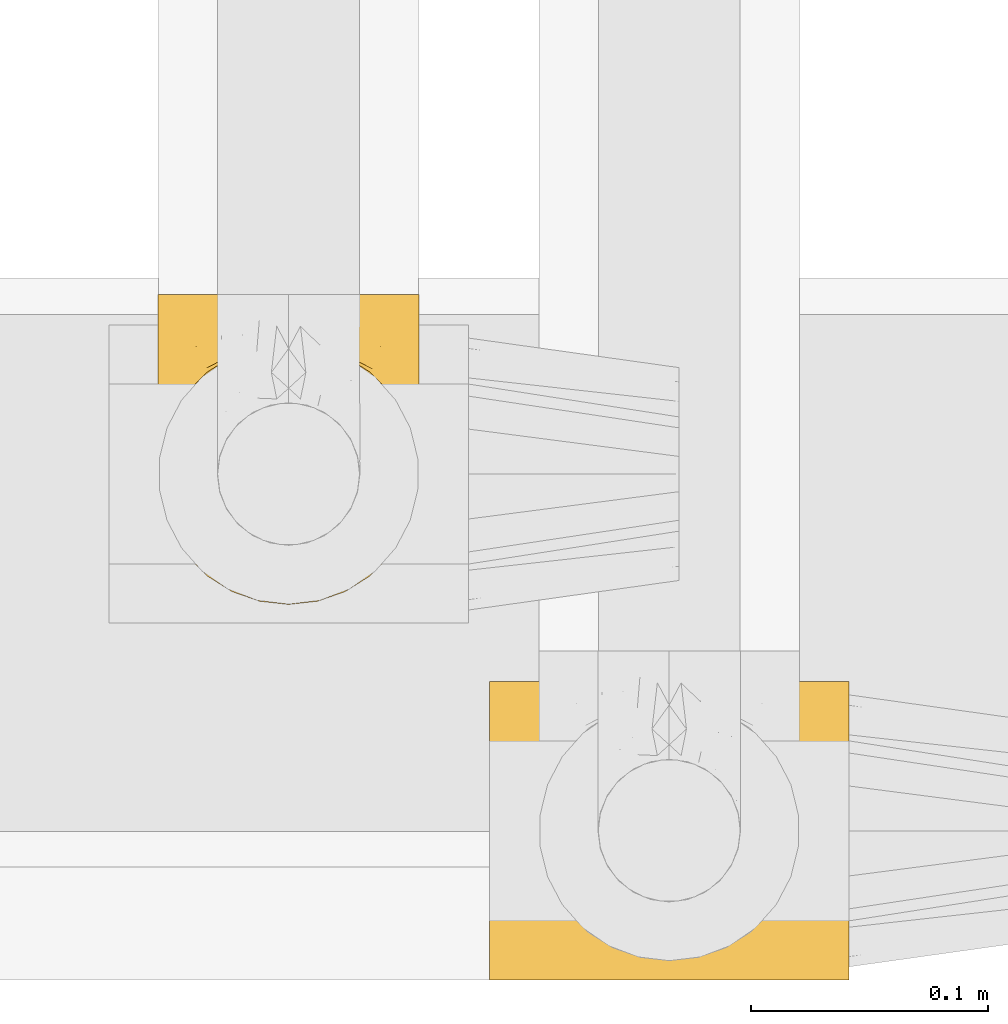
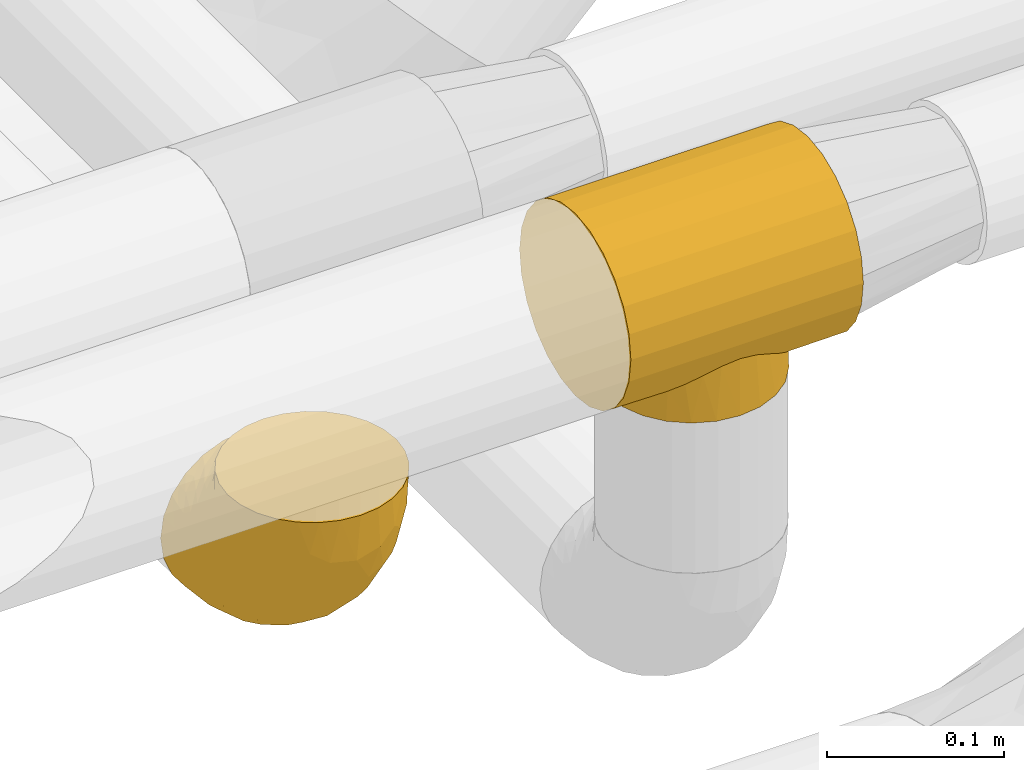
# One storey, part 183 of 827: 2 coverings.
"""IFC2X3 building model written with IfcOpenShell, lengths in millimetres."""

from ifc_helpers import new_model, entity, si_unit, converted_unit, derived_unit, direction, frame, origin, place, context, subcontext, project, spatial, faceted_brep, element, save


model = new_model("IFC2X3")

# Units and contexts
model_context = context("Model", 3, precision=0.01, world=origin(), true_north=direction((6.12303176911189e-17, 1.0)))
body_context = subcontext(model_context, "Body", "Model", "MODEL_VIEW")
ifc_project = project(units=[si_unit("LENGTHUNIT", "METRE", prefix="MILLI"), si_unit("AREAUNIT", "SQUARE_METRE"), si_unit("VOLUMEUNIT", "CUBIC_METRE"), converted_unit("PLANEANGLEUNIT", "DEGREE", entity("IfcRatioMeasure", 0.0174532925199433), si_unit("PLANEANGLEUNIT", "RADIAN"), dimensions=[0, 0, 0, 0, 0, 0, 0]), si_unit("MASSUNIT", "GRAM", prefix="KILO"), derived_unit("MASSDENSITYUNIT", [(si_unit("MASSUNIT", "GRAM", prefix="KILO"), 1), (si_unit("LENGTHUNIT", "METRE"), -3)]), derived_unit("MOMENTOFINERTIAUNIT", [(si_unit("LENGTHUNIT", "METRE"), 4)]), si_unit("TIMEUNIT", "SECOND"), si_unit("FREQUENCYUNIT", "HERTZ"), si_unit("THERMODYNAMICTEMPERATUREUNIT", "DEGREE_CELSIUS"), derived_unit("THERMALTRANSMITTANCEUNIT", [(si_unit("MASSUNIT", "GRAM", prefix="KILO"), 1), (si_unit("THERMODYNAMICTEMPERATUREUNIT", "KELVIN"), -1), (si_unit("TIMEUNIT", "SECOND"), -3)]), derived_unit("VOLUMETRICFLOWRATEUNIT", [(si_unit("LENGTHUNIT", "METRE"), 3), (si_unit("TIMEUNIT", "SECOND"), -1)]), derived_unit("MASSFLOWRATEUNIT", [(si_unit("MASSUNIT", "GRAM", prefix="KILO"), 1), (si_unit("TIMEUNIT", "SECOND"), -1)]), derived_unit("ROTATIONALFREQUENCYUNIT", [(si_unit("TIMEUNIT", "SECOND"), -1)]), si_unit("ELECTRICCURRENTUNIT", "AMPERE"), si_unit("ELECTRICVOLTAGEUNIT", "VOLT"), si_unit("POWERUNIT", "WATT"), si_unit("FORCEUNIT", "NEWTON", prefix="KILO"), si_unit("ILLUMINANCEUNIT", "LUX"), si_unit("LUMINOUSFLUXUNIT", "LUMEN"), si_unit("LUMINOUSINTENSITYUNIT", "CANDELA"), derived_unit("USERDEFINED", [(si_unit("MASSUNIT", "GRAM", prefix="KILO"), -1), (si_unit("LENGTHUNIT", "METRE"), -2), (si_unit("TIMEUNIT", "SECOND"), 3), (si_unit("LUMINOUSFLUXUNIT", "LUMEN"), 1)]), derived_unit("LINEARVELOCITYUNIT", [(si_unit("LENGTHUNIT", "METRE"), 1), (si_unit("TIMEUNIT", "SECOND"), -1)]), si_unit("PRESSUREUNIT", "PASCAL"), derived_unit("USERDEFINED", [(si_unit("LENGTHUNIT", "METRE"), -2), (si_unit("MASSUNIT", "GRAM", prefix="KILO"), 1), (si_unit("TIMEUNIT", "SECOND"), -2)]), derived_unit("LINEARFORCEUNIT", [(si_unit("MASSUNIT", "GRAM", prefix="KILO"), 1), (si_unit("LENGTHUNIT", "METRE"), 1), (si_unit("TIMEUNIT", "SECOND"), -2), (si_unit("LENGTHUNIT", "METRE"), -1)]), derived_unit("PLANARFORCEUNIT", [(si_unit("MASSUNIT", "GRAM", prefix="KILO"), 1), (si_unit("LENGTHUNIT", "METRE"), 1), (si_unit("TIMEUNIT", "SECOND"), -2), (si_unit("LENGTHUNIT", "METRE"), -2)])], contexts=[model_context])

# Site, building, storey
site_placement = place(None, origin())
site = spatial("IfcSite", under=ifc_project, at=site_placement, CompositionType="ELEMENT")
building_placement = place(site_placement, origin())
building = spatial("IfcBuilding", under=site, at=building_placement, CompositionType="ELEMENT")
storey_placement = place(building_placement, frame((0.0, 0.0, 28200.0)))
storey = spatial("IfcBuildingStorey", under=building, at=storey_placement, Name="08", CompositionType="ELEMENT", Elevation=28200.0)

# Coverings
covering_1_placement = place(storey_placement, frame((36553.64, 6201.06, 3029.92)))
element("IfcCovering", 1, at=covering_1_placement, inside=storey, Name=":ADSK_", ObjectType=":ADSK_", PredefinedType="INSULATION", context=body_context, shape_type="Brep", body=[
    faceted_brep([(152.0, 96.09, 124.73), (152.0, 80.87, 131.01), (152.0, 64.55, 133.13), (152.0, 48.24, 130.96), (152.0, 33.04, 124.64), (152.0, 20.0, 114.6), (152.0, 10.0, 101.53), (152.0, 3.72, 86.31), (152.0, 1.6, 69.99), (152.0, 3.77, 53.67), (152.0, 10.09, 38.48), (152.0, 15.11, 31.95), (152.0, 20.13, 25.43), (152.0, 26.66, 20.43), (152.0, 33.2, 15.43), (152.0, 40.81, 12.29), (152.0, 48.42, 9.16), (152.0, 52.5, 8.62), (152.0, 56.58, 8.09), (152.0, 60.66, 7.56), (152.0, 64.74, 7.03), (152.0, 68.82, 7.57), (152.0, 72.9, 8.12), (152.0, 76.97, 8.66), (152.0, 81.05, 9.2), (152.0, 88.65, 12.36), (152.0, 96.25, 15.52), (152.0, 102.77, 20.54), (152.0, 109.29, 25.56), (152.0, 114.29, 32.1), (152.0, 119.29, 38.64), (152.0, 125.57, 53.85), (152.0, 127.7, 70.17), (152.0, 125.52, 86.49), (152.0, 119.2, 101.69), (152.0, 109.16, 114.73), (0.0, 1.6, 69.99), (0.0, 3.72, 86.31), (0.0, 10.0, 101.53), (0.0, 20.0, 114.6), (0.0, 33.04, 124.64), (0.0, 48.24, 130.96), (0.0, 64.55, 133.13), (0.0, 80.87, 131.01), (0.0, 96.09, 124.73), (0.0, 109.16, 114.73), (0.0, 119.2, 101.69), (0.0, 125.52, 86.49), (0.0, 127.7, 70.17), (0.0, 125.57, 53.85), (0.0, 119.29, 38.64), (0.0, 114.29, 32.1), (0.0, 109.29, 25.56), (0.0, 102.77, 20.54), (0.0, 96.25, 15.52), (0.0, 88.65, 12.36), (0.0, 81.05, 9.2), (0.0, 76.97, 8.66), (0.0, 72.9, 8.12), (0.0, 68.82, 7.57), (0.0, 64.74, 7.03), (0.0, 60.66, 7.56), (0.0, 56.58, 8.09), (0.0, 52.5, 8.62), (0.0, 48.42, 9.16), (0.0, 40.81, 12.29), (0.0, 33.2, 15.43), (0.0, 26.66, 20.43), (0.0, 20.13, 25.43), (0.0, 15.11, 31.95), (0.0, 10.09, 38.48), (0.0, 3.77, 53.67), (76.0, 9.54, 39.44), (37.61, 25.12, 20.96), (45.48, 18.77, 26.83), (54.43, 13.94, 32.6), (126.44, 42.42, 11.08), (64.6, 10.74, 37.39), (106.52, 18.77, 26.83), (97.57, 13.94, 32.6), (87.4, 10.74, 37.39), (131.15, 64.74, 7.03), (20.85, 64.74, 7.03), (114.39, 25.12, 20.96), (121.12, 33.01, 15.54), (21.46, 58.95, 7.56), (28.22, 37.72, 13.31), (25.56, 42.42, 11.08), (22.08, 53.17, 8.08), (30.88, 33.01, 15.54), (128.18, 47.79, 9.58), (129.92, 53.17, 8.08), (23.82, 47.79, 9.58), (130.54, 58.95, 7.56), (123.78, 37.72, 13.31), (21.46, 70.52, 7.58), (22.08, 76.31, 8.12), (30.88, 96.44, 15.64), (28.22, 91.74, 13.39), (126.44, 87.04, 11.14), (123.78, 91.74, 13.39), (25.56, 87.04, 11.14), (23.82, 81.67, 9.63), (129.92, 76.31, 8.12), (130.54, 70.52, 7.58), (128.18, 81.67, 9.63), (121.12, 96.44, 15.64), (114.39, 104.31, 21.07), (45.48, 110.64, 26.96), (54.43, 115.46, 32.75), (37.61, 104.31, 21.07), (64.6, 118.65, 37.54), (76.0, 119.84, 39.6), (97.57, 115.46, 32.75), (106.52, 110.64, 26.96), (87.4, 118.65, 37.54), (76.0, 9.6, 0.0), (61.73, 11.48, 0.0), (48.42, 16.99, 0.01), (37.0, 25.75, 0.02), (28.24, 37.17, 0.04), (25.48, 43.82, 0.05), (22.73, 50.47, 0.06), (21.79, 57.61, 0.07), (20.85, 64.75, 0.08), (21.79, 71.89, 0.09), (22.73, 79.02, 0.1), (25.48, 85.67, 0.11), (28.24, 92.32, 0.12), (37.0, 103.75, 0.14), (48.42, 112.51, 0.15), (61.73, 118.02, 0.16), (76.0, 119.9, 0.16), (90.27, 118.02, 0.16), (103.57, 112.51, 0.15), (115.0, 103.75, 0.14), (123.76, 92.32, 0.12), (126.52, 85.67, 0.11), (129.27, 79.02, 0.1), (130.21, 71.89, 0.09), (131.15, 64.75, 0.08), (130.21, 57.61, 0.07), (129.27, 50.47, 0.06), (126.52, 43.82, 0.05), (123.76, 37.17, 0.04), (115.0, 25.75, 0.02), (103.57, 16.99, 0.01), (90.27, 11.48, 0.0)], [[[0, 1, 2, 3, 4, 5, 6, 7, 8, 9, 10, 11, 12, 13, 14, 15, 16, 17, 18, 19, 20, 21, 22, 23, 24, 25, 26, 27, 28, 29, 30, 31, 32, 33, 34, 35]], [[36, 37, 38, 39, 40, 41, 42, 43, 44, 45, 46, 47, 48, 49, 50, 51, 52, 53, 54, 55, 56, 57, 58, 59, 60, 61, 62, 63, 64, 65, 66, 67, 68, 69, 70, 71]], [[40, 39, 5, 4]], [[2, 42, 41, 3]], [[4, 3, 41, 40]], [[6, 38, 37, 7]], [[7, 37, 36, 8]], [[5, 39, 38, 6]], [[71, 9, 8, 36]], [[70, 72, 71]], [[73, 68, 67]], [[74, 75, 69]], [[76, 16, 15]], [[77, 70, 75]], [[78, 11, 79]], [[69, 68, 74]], [[77, 72, 70]], [[9, 71, 72]], [[10, 9, 72]], [[72, 80, 10]], [[79, 11, 10]], [[19, 81, 20]], [[82, 61, 60]], [[12, 11, 78]], [[83, 12, 78]], [[84, 13, 83]], [[79, 10, 80]], [[75, 70, 69]], [[73, 74, 68]], [[85, 62, 61]], [[86, 66, 65]], [[87, 65, 64]], [[88, 64, 63, 62]], [[73, 67, 89]], [[16, 76, 90, 91]], [[89, 67, 66]], [[85, 61, 82]], [[88, 62, 85]], [[65, 87, 86]], [[64, 88, 92, 87]], [[18, 91, 93]], [[84, 14, 13]], [[94, 14, 84]], [[15, 94, 76]], [[91, 18, 17, 16]], [[83, 13, 12]], [[19, 18, 93]], [[81, 19, 93]], [[14, 94, 15]], [[66, 86, 89]], [[58, 95, 59]], [[96, 58, 57, 56]], [[58, 96, 95]], [[97, 98, 54]], [[25, 99, 100]], [[101, 55, 98]], [[53, 97, 54]], [[56, 101, 102, 96]], [[103, 24, 23, 22]], [[103, 22, 104]], [[81, 21, 20]], [[59, 82, 60]], [[104, 22, 21]], [[104, 21, 81]], [[105, 99, 24, 103]], [[82, 59, 95]], [[106, 107, 27]], [[108, 51, 109]], [[99, 25, 24]], [[100, 26, 25]], [[101, 56, 55]], [[97, 53, 110]], [[53, 52, 110]], [[54, 98, 55]], [[52, 51, 108]], [[50, 111, 109]], [[109, 51, 50]], [[26, 100, 106]], [[112, 49, 31]], [[50, 112, 111]], [[112, 50, 49]], [[49, 48, 32, 31]], [[113, 30, 29]], [[113, 29, 114]], [[27, 26, 106]], [[28, 107, 114]], [[29, 28, 114]], [[115, 30, 113]], [[115, 112, 30]], [[30, 112, 31]], [[107, 28, 27]], [[108, 110, 52]], [[33, 47, 46, 34]], [[34, 46, 45, 35]], [[48, 47, 33, 32]], [[0, 44, 43, 1]], [[1, 43, 42, 2]], [[35, 45, 44, 0]], [[116, 117, 118, 119, 120, 121, 122, 123, 124, 125, 126, 127, 128, 129, 130, 131, 132, 133, 134, 135, 136, 137, 138, 139, 140, 141, 142, 143, 144, 145, 146, 147]], [[88, 123, 122]], [[121, 120, 87]], [[121, 92, 122]], [[119, 89, 120]], [[124, 85, 82]], [[124, 123, 85]], [[92, 121, 87]], [[120, 89, 86, 87]], [[88, 122, 92]], [[123, 88, 85]], [[119, 73, 89]], [[74, 73, 118]], [[118, 73, 119]], [[75, 118, 117]], [[77, 117, 116]], [[74, 118, 75]], [[77, 75, 117]], [[72, 77, 116]], [[80, 116, 147]], [[147, 146, 79]], [[83, 146, 145]], [[83, 78, 146]], [[72, 116, 80]], [[80, 147, 79]], [[146, 78, 79]], [[145, 144, 84]], [[142, 91, 90]], [[142, 90, 143]], [[140, 81, 93]], [[91, 142, 141]], [[144, 76, 94, 84]], [[76, 144, 143]], [[91, 141, 93]], [[143, 90, 76]], [[140, 93, 141]], [[145, 84, 83]], [[103, 139, 138]], [[137, 136, 99]], [[135, 106, 136]], [[140, 104, 81]], [[140, 139, 104]], [[105, 137, 99]], [[136, 106, 100, 99]], [[103, 138, 105]], [[137, 105, 138]], [[135, 107, 106]], [[114, 107, 134]], [[134, 107, 135]], [[113, 134, 133]], [[115, 133, 132]], [[114, 134, 113]], [[115, 113, 133]], [[112, 115, 132]], [[139, 103, 104]], [[111, 132, 131]], [[131, 130, 109]], [[110, 130, 129]], [[110, 108, 130]], [[112, 132, 111]], [[111, 131, 109]], [[130, 108, 109]], [[124, 95, 125]], [[97, 129, 128]], [[126, 102, 127]], [[95, 124, 82]], [[96, 126, 125]], [[128, 101, 98, 97]], [[101, 128, 127]], [[96, 125, 95]], [[127, 102, 101]], [[126, 96, 102]], [[129, 97, 110]]]),
])
covering_2_placement = place(storey_placement, frame((36411.97, 6359.82, 2793.25)))
element("IfcCovering", 2, at=covering_2_placement, inside=storey, Name=":ADSK_", ObjectType=":ADSK_", PredefinedType="INSULATION", context=body_context, shape_type="Brep", body=[
    faceted_brep([(1.6, 56.75, 132.75), (2.98, 44.47, 132.75), (7.06, 32.81, 132.75), (13.63, 22.35, 132.75), (22.37, 13.62, 132.75), (32.83, 7.05, 132.75), (44.49, 2.97, 132.75), (56.75, 1.6, 132.75), (69.02, 2.98, 132.75), (80.68, 7.06, 132.75), (91.14, 13.63, 132.75), (99.87, 22.37, 132.75), (106.44, 32.83, 132.75), (110.52, 44.49, 132.75), (111.9, 56.75, 132.75), (110.94, 65.19, 132.75), (110.51, 69.02, 132.75), (108.47, 74.85, 132.75), (106.43, 80.68, 132.75), (99.86, 91.14, 132.75), (91.12, 99.87, 132.75), (80.66, 106.44, 132.75), (69.0, 110.52, 132.75), (56.75, 111.9, 132.75), (44.47, 110.51, 132.75), (32.81, 106.43, 132.75), (22.35, 99.86, 132.75), (13.62, 91.12, 132.75), (7.05, 80.66, 132.75), (5.01, 74.83, 132.75), (2.97, 69.0, 132.75), (2.55, 65.19, 132.75), (71.02, 132.75, 110.02), (84.32, 132.75, 104.51), (95.74, 132.75, 95.74), (100.12, 132.75, 90.03), (104.51, 132.75, 84.32), (110.02, 132.75, 71.02), (110.78, 132.75, 65.22), (111.34, 132.75, 60.98), (111.9, 132.75, 56.75), (110.02, 132.75, 42.47), (104.51, 132.75, 29.17), (95.74, 132.75, 17.75), (84.32, 132.75, 8.98), (71.02, 132.75, 3.47), (56.75, 132.75, 1.6), (42.47, 132.75, 3.47), (29.17, 132.75, 8.98), (17.75, 132.75, 17.75), (8.98, 132.75, 29.17), (3.47, 132.75, 42.47), (1.6, 132.75, 56.75), (2.71, 132.75, 65.22), (3.47, 132.75, 71.02), (8.98, 132.75, 84.32), (13.37, 132.75, 90.03), (17.75, 132.75, 95.74), (29.17, 132.75, 104.51), (42.47, 132.75, 110.02), (56.75, 132.75, 111.9), (7.44, 106.09, 35.64), (2.99, 106.29, 48.47), (56.75, 98.8, 6.06), (46.96, 110.62, 4.36), (37.21, 79.56, 16.79), (27.14, 82.88, 20.82), (37.53, 101.82, 8.85), (24.94, 109.51, 13.94), (3.17, 60.24, 80.96), (1.6, 62.53, 103.66), (1.6, 66.65, 97.5), (1.6, 70.77, 91.33), (1.6, 74.89, 85.17), (1.6, 79.01, 79.01), (5.69, 75.42, 54.67), (12.02, 78.6, 38.99), (39.71, 54.94, 30.54), (56.75, 67.17, 19.17), (56.75, 40.01, 40.01), (15.45, 101.35, 24.66), (11.78, 27.42, 109.14), (56.75, 6.06, 98.8), (40.29, 7.89, 101.8), (9.49, 54.81, 63.23), (2.53, 49.8, 109.61), (2.41, 83.59, 62.85), (1.6, 85.17, 74.89), (1.6, 91.33, 70.77), (1.6, 97.5, 66.65), (1.6, 103.66, 62.53), (20.26, 19.66, 101.4), (15.42, 32.92, 80.83), (47.01, 86.86, 10.81), (31.45, 19.74, 79.3), (42.38, 29.98, 54.37), (44.67, 15.6, 76.81), (29.07, 11.19, 109.78), (29.36, 42.02, 48.41), (1.6, 58.54, 123.73), (1.6, 60.33, 114.72), (22.77, 25.28, 80.6), (24.08, 62.01, 35.27), (7.53, 42.85, 86.96), (6.23, 37.14, 110.67), (56.75, 19.17, 67.17), (17.33, 51.44, 52.02), (1.6, 114.72, 60.33), (1.6, 119.22, 59.44), (1.6, 123.73, 58.54), (6.73, 115.76, 82.8), (2.92, 110.4, 72.79), (3.19, 102.67, 77.6), (3.2, 119.74, 71.3), (19.32, 125.52, 98.0), (12.48, 123.09, 90.73), (14.6, 115.24, 96.3), (7.81, 124.18, 82.91), (7.5, 108.76, 87.53), (9.9, 105.53, 94.55), (45.9, 112.2, 125.07), (31.09, 109.92, 117.99), (35.08, 108.4, 125.94), (9.55, 89.3, 113.64), (3.53, 78.37, 103.99), (4.99, 78.09, 116.68), (17.56, 110.58, 102.88), (22.47, 108.54, 110.61), (31.26, 114.9, 112.36), (44.17, 124.4, 112.06), (25.83, 124.83, 103.46), (13.83, 92.2, 124.54), (20.99, 100.98, 120.6), (2.74, 69.61, 118.13), (4.52, 87.39, 96.16), (18.5, 102.3, 113.04), (2.46, 70.27, 110.58), (43.31, 116.83, 116.83), (56.75, 114.69, 122.32), (56.75, 122.32, 114.69), (8.84, 94.21, 103.01), (29.08, 120.17, 107.4), (7.16, 96.46, 95.69), (4.76, 97.77, 87.01), (3.35, 89.34, 88.18), (13.82, 101.91, 105.15), (84.41, 120.17, 107.4), (87.67, 124.84, 103.46), (110.29, 102.67, 77.6), (111.9, 97.5, 66.65), (110.57, 110.4, 72.79), (69.32, 124.4, 112.06), (111.9, 58.54, 123.73), (111.9, 60.33, 114.72), (110.14, 89.33, 88.19), (111.9, 79.01, 79.01), (111.9, 85.17, 74.89), (70.16, 116.83, 116.83), (67.57, 112.21, 125.08), (92.48, 101.0, 120.61), (82.38, 109.94, 117.98), (78.39, 108.4, 125.94), (111.9, 114.72, 60.33), (111.9, 123.73, 58.54), (111.9, 128.24, 57.64), (95.92, 110.6, 102.88), (91.0, 108.57, 110.61), (99.66, 101.94, 105.15), (94.16, 125.53, 98.0), (101.59, 119.28, 90.96), (108.5, 78.12, 116.68), (111.9, 103.66, 62.53), (110.29, 119.74, 71.3), (106.76, 115.76, 82.8), (105.99, 108.77, 87.53), (105.68, 124.18, 82.91), (108.96, 87.39, 96.19), (111.9, 74.89, 85.17), (111.9, 62.53, 103.66), (110.74, 69.63, 118.15), (99.65, 92.22, 124.54), (94.97, 102.32, 113.04), (103.92, 89.33, 113.63), (109.95, 78.39, 103.99), (103.58, 105.54, 94.56), (111.03, 70.28, 110.59), (111.9, 66.65, 97.5), (98.89, 115.25, 96.3), (104.63, 94.22, 103.04), (106.33, 96.46, 95.7), (108.72, 97.78, 87.02), (82.21, 114.91, 112.37), (111.9, 70.77, 91.33), (111.9, 91.33, 70.77), (111.08, 83.59, 62.85), (106.06, 106.09, 35.64), (105.97, 42.86, 86.97), (110.32, 60.25, 80.97), (110.96, 49.81, 109.62), (66.48, 88.41, 10.24), (110.5, 106.29, 48.47), (75.96, 101.81, 8.85), (66.4, 110.86, 4.3), (88.55, 109.5, 13.95), (98.04, 101.34, 24.66), (86.35, 82.87, 20.83), (84.14, 42.02, 48.41), (71.11, 29.98, 54.37), (73.77, 54.94, 30.54), (107.8, 75.43, 54.67), (96.17, 51.45, 52.03), (101.47, 78.59, 39.0), (104.01, 54.82, 63.25), (101.72, 27.44, 109.14), (98.08, 32.93, 80.83), (82.06, 19.76, 79.27), (93.25, 19.67, 101.39), (90.73, 25.31, 80.58), (89.43, 62.02, 35.28), (73.22, 7.9, 101.78), (84.44, 11.2, 109.77), (70.22, 15.96, 76.83), (75.29, 77.26, 17.47), (107.27, 37.15, 110.68)], [[[0, 1, 2, 3, 4, 5, 6, 7, 8, 9, 10, 11, 12, 13, 14, 15, 16, 17, 18, 19, 20, 21, 22, 23, 24, 25, 26, 27, 28, 29, 30, 31]], [[32, 33, 34, 35, 36, 37, 38, 39, 40, 41, 42, 43, 44, 45, 46, 47, 48, 49, 50, 51, 52, 53, 54, 55, 56, 57, 58, 59, 60]], [[51, 61, 62]], [[46, 63, 64]], [[65, 66, 67]], [[67, 66, 68]], [[69, 70, 71, 72, 73, 74]], [[75, 61, 76]], [[77, 78, 79]], [[61, 50, 80]], [[49, 80, 50]], [[68, 49, 48]], [[81, 3, 2]], [[82, 6, 83]], [[48, 47, 67]], [[52, 51, 62]], [[84, 75, 76]], [[85, 1, 0]], [[86, 74, 87, 88, 89, 90]], [[91, 81, 92]], [[93, 65, 67]], [[94, 95, 96]], [[49, 68, 80]], [[79, 95, 77]], [[5, 83, 6]], [[82, 83, 96]], [[97, 5, 4]], [[6, 82, 7]], [[84, 69, 75]], [[86, 69, 74]], [[98, 77, 95]], [[97, 83, 5]], [[85, 0, 99, 100, 70]], [[101, 91, 92]], [[77, 98, 102]], [[91, 4, 3]], [[103, 104, 85]], [[103, 81, 104]], [[102, 76, 80]], [[64, 93, 67]], [[97, 94, 83]], [[47, 64, 67]], [[50, 61, 51]], [[81, 91, 3]], [[96, 95, 105]], [[79, 105, 95]], [[101, 98, 94]], [[4, 91, 97]], [[94, 97, 91]], [[104, 81, 2]], [[92, 81, 103]], [[84, 92, 103]], [[106, 98, 101]], [[76, 61, 80]], [[75, 86, 62]], [[102, 80, 66]], [[84, 76, 106]], [[75, 62, 61]], [[62, 90, 107, 108, 109, 52]], [[70, 69, 85]], [[103, 85, 69]], [[94, 98, 95]], [[102, 98, 106]], [[2, 1, 104]], [[85, 104, 1]], [[67, 68, 48]], [[80, 68, 66]], [[62, 86, 90]], [[69, 86, 75]], [[76, 102, 106]], [[77, 102, 66]], [[92, 84, 106]], [[69, 84, 103]], [[46, 64, 47]], [[93, 64, 63]], [[63, 78, 93]], [[77, 93, 78]], [[93, 77, 65]], [[77, 66, 65]], [[82, 96, 105]], [[94, 96, 83]], [[101, 92, 106]], [[94, 91, 101]], [[110, 111, 112]], [[107, 90, 113]], [[114, 115, 116]], [[54, 107, 113]], [[115, 56, 117]], [[118, 119, 116]], [[120, 121, 122]], [[123, 124, 125]], [[99, 0, 31, 30, 100]], [[126, 127, 128]], [[129, 60, 59]], [[58, 114, 130]], [[131, 132, 123]], [[29, 28, 133]], [[130, 59, 58]], [[114, 58, 57]], [[134, 72, 124]], [[121, 127, 135]], [[26, 25, 132]], [[27, 131, 125]], [[27, 125, 28]], [[136, 133, 125]], [[120, 137, 121]], [[137, 138, 139]], [[126, 116, 119]], [[133, 70, 100]], [[138, 120, 23]], [[100, 29, 133]], [[123, 135, 140]], [[129, 141, 128]], [[53, 52, 109, 108, 107, 54]], [[25, 122, 132]], [[24, 122, 25]], [[55, 113, 117]], [[26, 131, 27]], [[142, 119, 143]], [[111, 89, 112]], [[112, 87, 143]], [[144, 134, 142]], [[118, 110, 112]], [[129, 137, 139]], [[128, 141, 126]], [[111, 113, 90]], [[54, 113, 55]], [[74, 73, 144]], [[145, 142, 140]], [[122, 24, 120]], [[132, 122, 121]], [[23, 120, 24]], [[137, 120, 138]], [[60, 129, 139]], [[141, 129, 59]], [[100, 30, 29]], [[28, 125, 133]], [[134, 124, 123]], [[124, 71, 136]], [[89, 88, 87, 112]], [[111, 110, 117]], [[143, 87, 144]], [[118, 116, 115]], [[112, 143, 118]], [[119, 118, 143]], [[143, 144, 142]], [[126, 119, 145]], [[127, 126, 145]], [[130, 126, 141]], [[140, 142, 134]], [[145, 119, 142]], [[135, 127, 145]], [[127, 121, 128]], [[121, 137, 128]], [[129, 128, 137]], [[73, 72, 134]], [[111, 90, 89]], [[74, 144, 87]], [[134, 123, 140]], [[135, 123, 132]], [[140, 135, 145]], [[121, 135, 132]], [[132, 131, 26]], [[125, 131, 123]], [[115, 114, 57]], [[116, 126, 130]], [[111, 117, 113]], [[115, 110, 118]], [[115, 117, 110]], [[115, 57, 56]], [[56, 55, 117]], [[116, 130, 114]], [[59, 130, 141]], [[144, 73, 134]], [[124, 136, 125]], [[70, 133, 136]], [[71, 124, 72]], [[71, 70, 136]], [[32, 146, 147]], [[148, 149, 150]], [[60, 139, 151]], [[15, 14, 152, 153, 16]], [[154, 155, 156]], [[138, 157, 139]], [[138, 158, 157]], [[159, 160, 161]], [[39, 38, 37, 162, 163, 164, 40]], [[165, 166, 167]], [[168, 169, 34]], [[33, 168, 34]], [[170, 19, 18]], [[171, 162, 172]], [[173, 174, 148]], [[169, 173, 175]], [[161, 158, 22]], [[154, 176, 177]], [[23, 22, 158]], [[178, 179, 153]], [[172, 37, 36]], [[20, 19, 180]], [[21, 20, 159]], [[167, 166, 181]], [[170, 182, 180]], [[182, 170, 183]], [[167, 184, 165]], [[185, 186, 183]], [[170, 179, 185]], [[17, 153, 179]], [[157, 151, 139]], [[187, 168, 147]], [[182, 188, 181]], [[22, 21, 161]], [[189, 154, 190]], [[180, 159, 20]], [[172, 150, 171]], [[190, 184, 189]], [[188, 167, 181]], [[190, 174, 184]], [[166, 191, 160]], [[151, 146, 32]], [[37, 172, 162]], [[175, 36, 35]], [[188, 176, 189]], [[176, 182, 183]], [[159, 161, 21]], [[158, 160, 157]], [[158, 161, 160]], [[23, 158, 138]], [[151, 157, 191]], [[60, 151, 32]], [[170, 18, 179]], [[17, 16, 153]], [[183, 170, 185]], [[179, 178, 185]], [[175, 150, 172]], [[150, 173, 148]], [[173, 169, 174]], [[154, 156, 190]], [[184, 174, 187]], [[190, 148, 174]], [[165, 184, 187]], [[189, 176, 154]], [[147, 165, 187]], [[191, 166, 165]], [[184, 167, 189]], [[188, 189, 167]], [[191, 165, 146]], [[181, 160, 159]], [[151, 191, 146]], [[157, 160, 191]], [[176, 192, 177]], [[148, 190, 156]], [[149, 148, 156, 193]], [[149, 171, 150]], [[182, 176, 188]], [[160, 181, 166]], [[181, 159, 182]], [[170, 180, 19]], [[159, 180, 182]], [[147, 168, 33]], [[169, 168, 187]], [[174, 169, 187]], [[35, 169, 175]], [[150, 175, 173]], [[34, 169, 35]], [[172, 36, 175]], [[32, 147, 33]], [[147, 146, 165]], [[192, 176, 183]], [[155, 154, 177]], [[192, 183, 186]], [[185, 178, 186]], [[179, 18, 17]], [[194, 171, 149, 193, 156, 155]], [[195, 42, 41]], [[196, 197, 198]], [[78, 63, 199]], [[197, 155, 177, 192, 186, 178]], [[200, 40, 164, 163, 162, 171]], [[201, 199, 202]], [[203, 204, 205]], [[46, 45, 202]], [[206, 207, 208]], [[194, 197, 209]], [[203, 201, 44]], [[44, 201, 45]], [[43, 203, 44]], [[210, 211, 212]], [[204, 43, 42]], [[212, 197, 196]], [[78, 208, 79]], [[198, 178, 153, 152, 14]], [[204, 195, 211]], [[14, 13, 198]], [[196, 213, 214]], [[206, 215, 207]], [[213, 11, 216]], [[204, 42, 195]], [[11, 213, 12]], [[210, 217, 206]], [[216, 11, 10]], [[210, 206, 218]], [[219, 220, 9]], [[220, 10, 9]], [[207, 105, 79]], [[221, 207, 215]], [[222, 199, 201]], [[8, 7, 82]], [[8, 82, 219]], [[209, 195, 200]], [[215, 216, 220]], [[9, 8, 219]], [[207, 79, 208]], [[221, 82, 105]], [[12, 213, 223]], [[222, 201, 205]], [[204, 211, 218]], [[221, 215, 219]], [[215, 220, 219]], [[216, 10, 220]], [[214, 213, 216]], [[223, 213, 196]], [[217, 214, 216]], [[212, 214, 210]], [[200, 195, 41]], [[211, 195, 209]], [[212, 211, 209]], [[211, 210, 218]], [[40, 200, 41]], [[200, 171, 194]], [[198, 13, 223]], [[197, 178, 198]], [[218, 208, 205]], [[210, 214, 217]], [[198, 223, 196]], [[13, 12, 223]], [[204, 203, 43]], [[201, 203, 205]], [[197, 194, 155]], [[200, 194, 209]], [[208, 218, 206]], [[218, 205, 204]], [[197, 212, 209]], [[214, 212, 196]], [[205, 208, 222]], [[78, 222, 208]], [[78, 199, 222]], [[202, 199, 63]], [[46, 202, 63]], [[201, 202, 45]], [[82, 221, 219]], [[105, 207, 221]], [[216, 215, 217]], [[206, 217, 215]]]),
])

save(model, "model.ifc")
